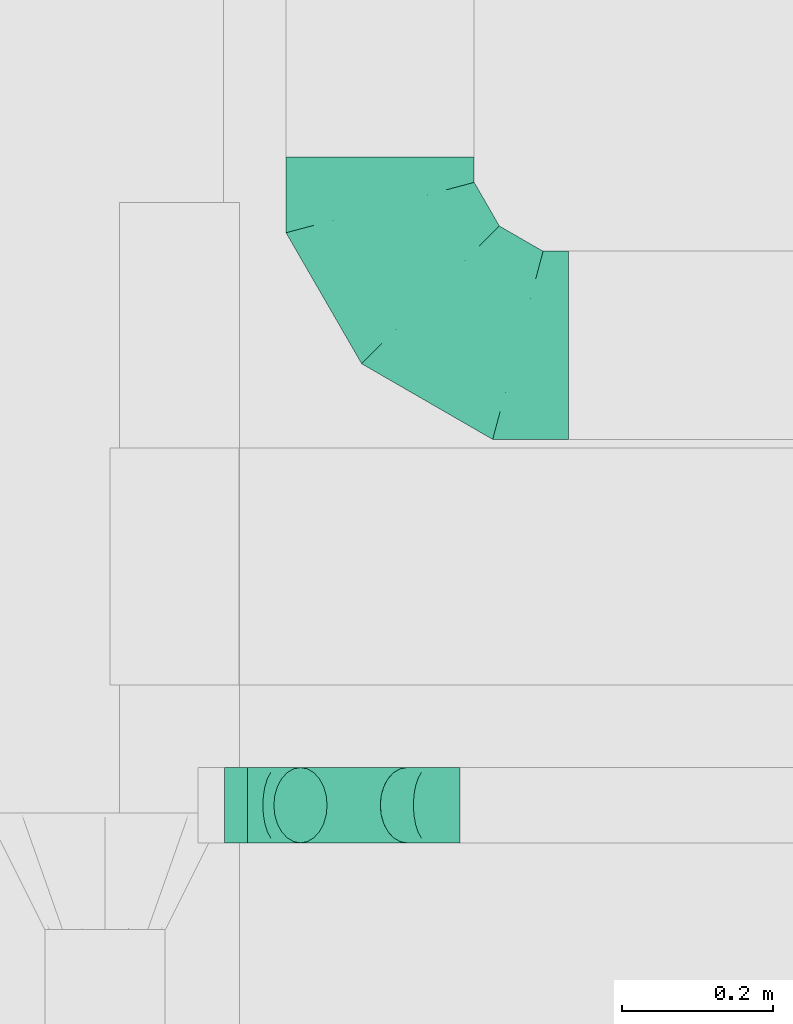
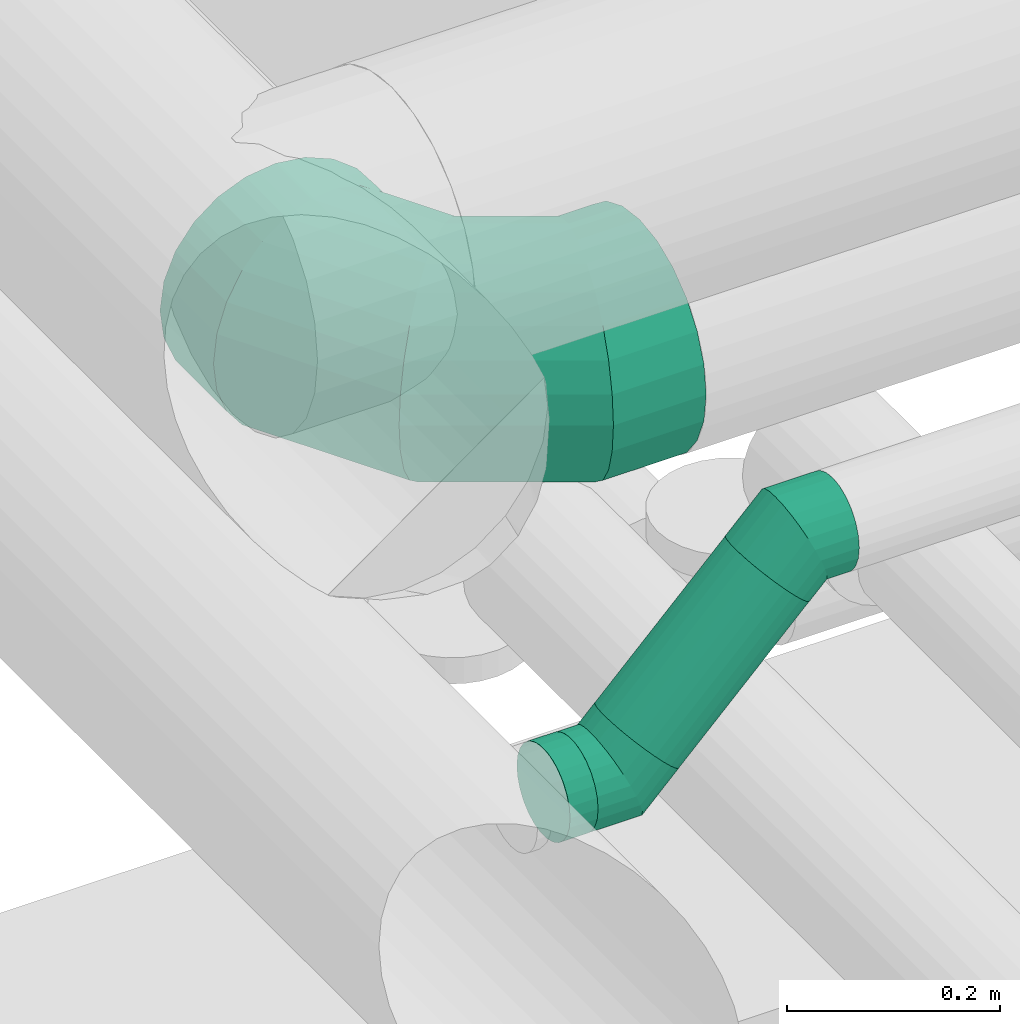
# One storey, part 119 of 337: 3 flow fittings, 2 flow segments.
"""IFC2X3 building model written with IfcOpenShell, lengths in millimetres."""

from ifc_helpers import new_model, entity, si_unit, converted_unit, derived_unit, direction, frame, origin, origin_2d_with_axis, place, context, subcontext, project, spatial, circle, extrude, faceted_brep, source, transform, mapped, material, type_object, type_shapes, element, save


model = new_model("IFC2X3")

# Units and contexts
model_context = context("Model", 3, precision=0.01, world=origin(), true_north=direction((6.12303176911189e-17, 1.0)))
body_context = subcontext(model_context, "Body", "Model", "MODEL_VIEW")
ifc_project = project(units=[si_unit("LENGTHUNIT", "METRE", prefix="MILLI"), si_unit("AREAUNIT", "SQUARE_METRE"), si_unit("VOLUMEUNIT", "CUBIC_METRE"), converted_unit("PLANEANGLEUNIT", "DEGREE", entity("IfcRatioMeasure", 0.0174532925199433), si_unit("PLANEANGLEUNIT", "RADIAN"), dimensions=[0, 0, 0, 0, 0, 0, 0]), si_unit("MASSUNIT", "GRAM", prefix="KILO"), derived_unit("MASSDENSITYUNIT", [(si_unit("MASSUNIT", "GRAM", prefix="KILO"), 1), (si_unit("LENGTHUNIT", "METRE"), -3)]), derived_unit("MOMENTOFINERTIAUNIT", [(si_unit("LENGTHUNIT", "METRE"), 4)]), si_unit("TIMEUNIT", "SECOND"), si_unit("FREQUENCYUNIT", "HERTZ"), si_unit("THERMODYNAMICTEMPERATUREUNIT", "DEGREE_CELSIUS"), derived_unit("THERMALTRANSMITTANCEUNIT", [(si_unit("MASSUNIT", "GRAM", prefix="KILO"), 1), (si_unit("THERMODYNAMICTEMPERATUREUNIT", "KELVIN"), -1), (si_unit("TIMEUNIT", "SECOND"), -3)]), derived_unit("VOLUMETRICFLOWRATEUNIT", [(si_unit("LENGTHUNIT", "METRE"), 3), (si_unit("TIMEUNIT", "SECOND"), -1)]), derived_unit("MASSFLOWRATEUNIT", [(si_unit("MASSUNIT", "GRAM", prefix="KILO"), 1), (si_unit("TIMEUNIT", "SECOND"), -1)]), derived_unit("ROTATIONALFREQUENCYUNIT", [(si_unit("TIMEUNIT", "SECOND"), -1)]), si_unit("ELECTRICCURRENTUNIT", "AMPERE"), si_unit("ELECTRICVOLTAGEUNIT", "VOLT"), si_unit("POWERUNIT", "WATT"), si_unit("FORCEUNIT", "NEWTON", prefix="KILO"), si_unit("ILLUMINANCEUNIT", "LUX"), si_unit("LUMINOUSFLUXUNIT", "LUMEN"), si_unit("LUMINOUSINTENSITYUNIT", "CANDELA"), derived_unit("USERDEFINED", [(si_unit("MASSUNIT", "GRAM", prefix="KILO"), -1), (si_unit("LENGTHUNIT", "METRE"), -2), (si_unit("TIMEUNIT", "SECOND"), 3), (si_unit("LUMINOUSFLUXUNIT", "LUMEN"), 1)]), derived_unit("LINEARVELOCITYUNIT", [(si_unit("LENGTHUNIT", "METRE"), 1), (si_unit("TIMEUNIT", "SECOND"), -1)]), si_unit("PRESSUREUNIT", "PASCAL"), derived_unit("USERDEFINED", [(si_unit("LENGTHUNIT", "METRE"), -2), (si_unit("MASSUNIT", "GRAM", prefix="KILO"), 1), (si_unit("TIMEUNIT", "SECOND"), -2)]), derived_unit("LINEARFORCEUNIT", [(si_unit("MASSUNIT", "GRAM", prefix="KILO"), 1), (si_unit("LENGTHUNIT", "METRE"), 1), (si_unit("TIMEUNIT", "SECOND"), -2), (si_unit("LENGTHUNIT", "METRE"), -1)]), derived_unit("PLANARFORCEUNIT", [(si_unit("MASSUNIT", "GRAM", prefix="KILO"), 1), (si_unit("LENGTHUNIT", "METRE"), 1), (si_unit("TIMEUNIT", "SECOND"), -2), (si_unit("LENGTHUNIT", "METRE"), -2)])], contexts=[model_context])

# Site, building, storey
site_placement = place(None, origin())
site = spatial("IfcSite", under=ifc_project, at=site_placement, CompositionType="ELEMENT")
building_placement = place(site_placement, origin())
building = spatial("IfcBuilding", under=site, at=building_placement, CompositionType="ELEMENT")
storey_placement = place(building_placement, origin())
storey = spatial("IfcBuildingStorey", under=building, at=storey_placement, CompositionType="ELEMENT", Elevation=0.0)

# Flow segments
duct_segment_type = type_object("IfcDuctSegmentType", PredefinedType="NOTDEFINED")
flow_segment_1_placement = place(storey_placement, frame((29784.24, 3857.96, 2948.4)))
element("IfcFlowSegment", 1, at=flow_segment_1_placement, inside=storey, type_object=duct_segment_type, context=body_context, shape_type="SweptSolid", body=[
    extrude(circle(Radius=50.0, at=origin_2d_with_axis()), frame((0.0, 51.6, 51.6), z_axis=(1.0, 0.0, 0.0), x_axis=(0.0, -1.0, 0.0)), (0.0, 0.0, 1.0), 30.2782005644054),
])
flow_segment_2_placement = place(storey_placement, frame((29848.28, 3857.96, 2992.34)))
element("IfcFlowSegment", 2, at=flow_segment_2_placement, inside=storey, type_object=duct_segment_type, context=body_context, shape_type="SweptSolid", body=[
    extrude(circle(Radius=50.0, at=origin_2d_with_axis()), frame((36.95, 51.6, 36.95), z_axis=(0.707106792500212, 0.0, 0.707106769872883), x_axis=(0.0, -1.0, 0.0)), (0.0, 0.0, 1.0), 200.000006400018),
])

# Flow fittings
ifc_material = material()
duct_fitting_type_1 = type_object("IfcDuctFittingType", PredefinedType="NOTDEFINED", material=ifc_material)
shared_shape_1 = source(origin(), body_context, "Body", "Brep", [
    faceted_brep([(-250.0, 0.0, -125.0), (-250.0, -32.35, -120.74), (-250.0, -62.5, -108.25), (-250.0, -88.39, -88.39), (-250.0, -108.25, -62.5), (-250.0, -120.74, -32.35), (-250.0, -125.0, 0.0), (-250.0, -120.74, 32.35), (-250.0, -108.25, 62.5), (-250.0, -88.39, 88.39), (-250.0, -62.5, 108.25), (-250.0, -32.35, 120.74), (-250.0, 0.0, 125.0), (-250.0, 32.35, 120.74), (-250.0, 62.5, 108.25), (-250.0, 88.39, 88.39), (-250.0, 108.25, 62.5), (-250.0, 120.74, 32.35), (-250.0, 125.0, 0.0), (-250.0, 120.74, -32.35), (-250.0, 108.25, -62.5), (-250.0, 88.39, -88.39), (-250.0, 62.5, -108.25), (-250.0, 32.35, -120.74), (-191.68, 32.35, 120.74), (-199.76, 62.5, 108.25), (-183.01, 0.0, 125.0), (-206.7, 88.39, 88.39), (-215.37, 120.74, 32.35), (-216.51, 125.0, 0.0), (-212.02, 108.25, 62.5), (-212.02, 108.25, -62.5), (-206.7, 88.39, -88.39), (-215.37, 120.74, -32.35), (-191.68, 32.35, -120.74), (-183.01, 0.0, -125.0), (-199.76, 62.5, -108.25), (-174.34, -32.35, -120.74), (-166.27, -62.5, -108.25), (-159.33, -88.39, -88.39), (-154.01, -108.25, -62.5), (-150.66, -120.74, -32.35), (-149.52, -125.0, 0.0), (-150.66, -120.74, 32.35), (-154.01, -108.25, 62.5), (-159.33, -88.39, 88.39), (-166.27, -62.5, 108.25), (-174.34, -32.35, 120.74), (-90.67, 90.67, 120.74), (-112.74, 112.74, 108.25), (-66.99, 66.99, 125.0), (-131.69, 131.69, 88.39), (-146.23, 146.23, 62.5), (-155.38, 155.38, 32.35), (-158.49, 158.49, 0.0), (-155.38, 155.38, -32.35), (-146.23, 146.23, -62.5), (-131.69, 131.69, -88.39), (-90.67, 90.67, -120.74), (-66.99, 66.99, -125.0), (-112.74, 112.74, -108.25), (-43.3, 43.3, -120.74), (-21.23, 21.23, -108.25), (-2.28, 2.28, -88.39), (12.26, -12.26, -62.5), (21.4, -21.4, -32.35), (24.52, -24.52, 0.0), (21.4, -21.4, 32.35), (12.26, -12.26, 62.5), (-2.28, 2.28, 88.39), (-21.23, 21.23, 108.25), (-43.3, 43.3, 120.74), (-32.35, 191.68, 120.74), (-62.5, 199.76, 108.25), (0.0, 183.01, 125.0), (-88.39, 206.7, 88.39), (-108.25, 212.02, 62.5), (-120.74, 215.37, 32.35), (-125.0, 216.51, 0.0), (-120.74, 215.37, -32.35), (-108.25, 212.02, -62.5), (-88.39, 206.7, -88.39), (-32.35, 191.68, -120.74), (0.0, 183.01, -125.0), (-62.5, 199.76, -108.25), (32.35, 174.34, -120.74), (62.5, 166.27, -108.25), (88.39, 159.33, -88.39), (108.25, 154.01, -62.5), (120.74, 150.66, -32.35), (125.0, 149.52, 0.0), (120.74, 150.66, 32.35), (108.25, 154.01, 62.5), (88.39, 159.33, 88.39), (62.5, 166.27, 108.25), (32.35, 174.34, 120.74), (-32.35, 250.0, -120.74), (-62.5, 250.0, -108.25), (-88.39, 250.0, -88.39), (-108.25, 250.0, -62.5), (-120.74, 250.0, -32.35), (-125.0, 250.0, 0.0), (-120.74, 250.0, 32.35), (-108.25, 250.0, 62.5), (-88.39, 250.0, 88.39), (-62.5, 250.0, 108.25), (-32.35, 250.0, 120.74), (0.0, 250.0, 125.0), (32.35, 250.0, 120.74), (62.5, 250.0, 108.25), (88.39, 250.0, 88.39), (108.25, 250.0, 62.5), (120.74, 250.0, 32.35), (125.0, 250.0, 0.0), (120.74, 250.0, -32.35), (108.25, 250.0, -62.5), (88.39, 250.0, -88.39), (62.5, 250.0, -108.25), (32.35, 250.0, -120.74), (0.0, 250.0, -125.0)], [[[0, 1, 2, 3, 4, 5, 6, 7, 8, 9, 10, 11, 12, 13, 14, 15, 16, 17, 18, 19, 20, 21, 22, 23]], [[24, 25, 14, 13]], [[26, 24, 13, 12]], [[14, 25, 27, 15]], [[28, 29, 18, 17]], [[30, 28, 17, 16]], [[15, 27, 30, 16]], [[20, 31, 32, 21]], [[33, 31, 20, 19]], [[18, 29, 33, 19]], [[34, 35, 0, 23]], [[36, 34, 23, 22]], [[21, 32, 36, 22]], [[1, 0, 35, 37]], [[2, 1, 37, 38]], [[38, 39, 3, 2]], [[5, 4, 40, 41]], [[6, 5, 41, 42]], [[39, 40, 4, 3]], [[6, 42, 43, 7]], [[7, 43, 44, 8]], [[8, 44, 45, 9]], [[9, 45, 46, 10]], [[10, 46, 47, 11]], [[26, 12, 11, 47]], [[48, 49, 25, 24]], [[50, 48, 24, 26]], [[27, 25, 49, 51]], [[52, 53, 28, 30]], [[51, 52, 30, 27]], [[29, 28, 53, 54]], [[55, 56, 31, 33]], [[54, 55, 33, 29]], [[32, 31, 56, 57]], [[58, 59, 35, 34]], [[60, 58, 34, 36]], [[57, 60, 36, 32]], [[37, 35, 59, 61]], [[38, 37, 61, 62]], [[39, 38, 62, 63]], [[41, 40, 64, 65]], [[42, 41, 65, 66]], [[63, 64, 40, 39]], [[43, 42, 66, 67]], [[44, 43, 67, 68]], [[68, 69, 45, 44]], [[46, 45, 69, 70]], [[47, 46, 70, 71]], [[26, 47, 71, 50]], [[72, 73, 49, 48]], [[74, 72, 48, 50]], [[51, 49, 73, 75]], [[76, 77, 53, 52]], [[75, 76, 52, 51]], [[54, 53, 77, 78]], [[79, 80, 56, 55]], [[78, 79, 55, 54]], [[57, 56, 80, 81]], [[82, 83, 59, 58]], [[84, 82, 58, 60]], [[81, 84, 60, 57]], [[61, 59, 83, 85]], [[62, 61, 85, 86]], [[63, 62, 86, 87]], [[65, 64, 88, 89]], [[66, 65, 89, 90]], [[87, 88, 64, 63]], [[67, 66, 90, 91]], [[68, 67, 91, 92]], [[92, 93, 69, 68]], [[70, 69, 93, 94]], [[71, 70, 94, 95]], [[50, 71, 95, 74]], [[96, 97, 98, 99, 100, 101, 102, 103, 104, 105, 106, 107, 108, 109, 110, 111, 112, 113, 114, 115, 116, 117, 118, 119]], [[72, 74, 107, 106]], [[73, 72, 106, 105]], [[75, 73, 105, 104]], [[77, 76, 103, 102]], [[78, 77, 102, 101]], [[75, 104, 103, 76]], [[78, 101, 100, 79]], [[79, 100, 99, 80]], [[80, 99, 98, 81]], [[84, 97, 96, 82]], [[82, 96, 119, 83]], [[84, 81, 98, 97]], [[83, 119, 118, 85]], [[85, 118, 117, 86]], [[116, 87, 86, 117]], [[88, 115, 114, 89]], [[89, 114, 113, 90]], [[115, 88, 87, 116]], [[91, 90, 113, 112]], [[92, 91, 112, 111]], [[111, 110, 93, 92]], [[95, 94, 109, 108]], [[74, 95, 108, 107]], [[110, 109, 94, 93]]]),
])
type_shapes(duct_fitting_type_1, [shared_shape_1])
flow_fitting_placement = place(storey_placement, frame((29991.01, 4520.47, 3000.0), z_axis=(0.0, 0.0, 1.0), x_axis=(0.0, -1.0, 0.0)))
element("IfcFlowFitting", 3, at=flow_fitting_placement, inside=storey, type_object=duct_fitting_type_1, material=ifc_material, context=body_context, shape_type="MappedRepresentation", body=[
    mapped(shared_shape_1, transform((0.0, 0.0, 0.0), scale=1.0)),
])
duct_fitting_type_2 = type_object("IfcDuctFittingType", PredefinedType="NOTDEFINED", material=ifc_material)
shared_shape_2 = source(origin(), body_context, "Body", "Brep", [
    faceted_brep([(-41.42, 0.0, -50.0), (-41.42, -12.94, -48.3), (-41.42, -25.0, -43.3), (-41.42, -35.36, -35.36), (-41.42, -43.3, -25.0), (-41.42, -48.3, -12.94), (-41.42, -50.0, 0.0), (-41.42, -48.3, 12.94), (-41.42, -43.3, 25.0), (-41.42, -35.36, 35.36), (-41.42, -25.0, 43.3), (-41.42, -12.94, 48.3), (-41.42, 0.0, 50.0), (-41.42, 12.94, 48.3), (-41.42, 25.0, 43.3), (-41.42, 35.36, 35.36), (-41.42, 43.3, 25.0), (-41.42, 48.3, 12.94), (-41.42, 50.0, 0.0), (-41.42, 48.3, -12.94), (-41.42, 43.3, -25.0), (-41.42, 35.36, -35.36), (-41.42, 25.0, -43.3), (-41.42, 12.94, -48.3), (-5.36, 12.94, 48.3), (-10.36, 25.0, 43.3), (0.0, 0.0, 50.0), (-14.64, 35.36, 35.36), (-20.0, 48.3, 12.94), (-20.71, 50.0, 0.0), (-17.94, 43.3, 25.0), (-17.94, 43.3, -25.0), (-14.64, 35.36, -35.36), (-20.0, 48.3, -12.94), (-5.36, 12.94, -48.3), (0.0, 0.0, -50.0), (-10.36, 25.0, -43.3), (5.36, -12.94, -48.3), (10.36, -25.0, -43.3), (14.64, -35.36, -35.36), (17.94, -43.3, -25.0), (20.0, -48.3, -12.94), (20.71, -50.0, 0.0), (20.0, -48.3, 12.94), (17.94, -43.3, 25.0), (14.64, -35.36, 35.36), (10.36, -25.0, 43.3), (5.36, -12.94, 48.3), (29.29, 29.29, 50.0), (20.14, 38.44, 48.3), (11.61, 46.97, 43.3), (4.29, 54.29, 35.36), (-1.33, 59.91, 25.0), (-4.86, 63.44, 12.94), (-6.07, 64.64, 0.0), (-4.86, 63.44, -12.94), (-1.33, 59.91, -25.0), (4.29, 54.29, -35.36), (11.61, 46.97, -43.3), (20.14, 38.44, -48.3), (29.29, 29.29, -50.0), (38.44, 20.14, -48.3), (46.97, 11.61, -43.3), (54.29, 4.29, -35.36), (59.91, -1.33, -25.0), (63.44, -4.86, -12.94), (64.64, -6.07, 0.0), (63.44, -4.86, 12.94), (59.91, -1.33, 25.0), (54.29, 4.29, 35.36), (46.97, 11.61, 43.3), (38.44, 20.14, 48.3)], [[[0, 1, 2, 3, 4, 5, 6, 7, 8, 9, 10, 11, 12, 13, 14, 15, 16, 17, 18, 19, 20, 21, 22, 23]], [[24, 25, 14, 13]], [[26, 24, 13, 12]], [[14, 25, 27, 15]], [[28, 29, 18, 17]], [[30, 28, 17, 16]], [[16, 15, 27, 30]], [[20, 31, 32, 21]], [[33, 31, 20, 19]], [[18, 29, 33, 19]], [[34, 35, 0, 23]], [[36, 34, 23, 22]], [[32, 36, 22, 21]], [[1, 0, 35, 37]], [[2, 1, 37, 38]], [[38, 39, 3, 2]], [[5, 4, 40, 41]], [[6, 5, 41, 42]], [[39, 40, 4, 3]], [[6, 42, 43, 7]], [[7, 43, 44, 8]], [[8, 44, 45, 9]], [[9, 45, 46, 10]], [[10, 46, 47, 11]], [[26, 12, 11, 47]], [[24, 26, 48, 49]], [[25, 24, 49, 50]], [[27, 25, 50, 51]], [[28, 30, 52, 53]], [[29, 28, 53, 54]], [[27, 51, 52, 30]], [[29, 54, 55, 33]], [[33, 55, 56, 31]], [[31, 56, 57, 32]], [[36, 58, 59, 34]], [[34, 59, 60, 35]], [[36, 32, 57, 58]], [[61, 62, 38, 37]], [[60, 61, 37, 35]], [[63, 39, 38, 62]], [[40, 64, 65, 41]], [[41, 65, 66, 42]], [[64, 40, 39, 63]], [[43, 42, 66, 67]], [[44, 43, 67, 68]], [[68, 69, 45, 44]], [[47, 46, 70, 71]], [[26, 47, 71, 48]], [[69, 70, 46, 45]], [[59, 58, 57, 56, 55, 54, 53, 52, 51, 50, 49, 48, 71, 70, 69, 68, 67, 66, 65, 64, 63, 62, 61, 60]]]),
])
type_shapes(duct_fitting_type_2, [shared_shape_2])
for number, where, z_axis, x_axis in (
    (4, (29855.94, 3909.56, 3000.0), (0.0, -1.0, 0.0), (1.0, 0.0, 0.0)),
    (5, (30055.94, 3909.56, 3200.0), (0.0, 1.0, 0.0), (0.707106792500155, 0.0, 0.70710676987294)),
):
    element("IfcFlowFitting", number, at=place(storey_placement, frame(where, z_axis=z_axis, x_axis=x_axis)), inside=storey, type_object=duct_fitting_type_2, material=ifc_material, context=body_context, shape_type="MappedRepresentation", body=[
        mapped(shared_shape_2, transform((0.0, 0.0, 0.0), scale=1.0)),
    ])

save(model, "model.ifc")
